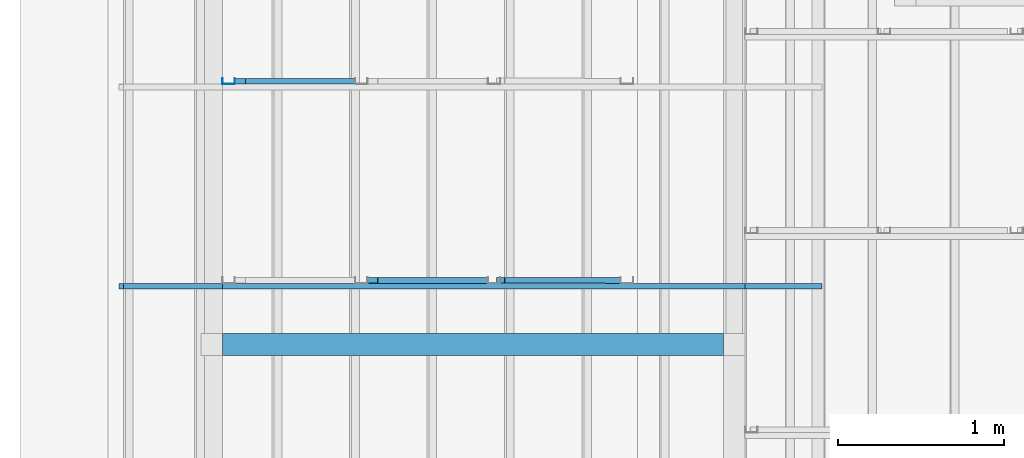
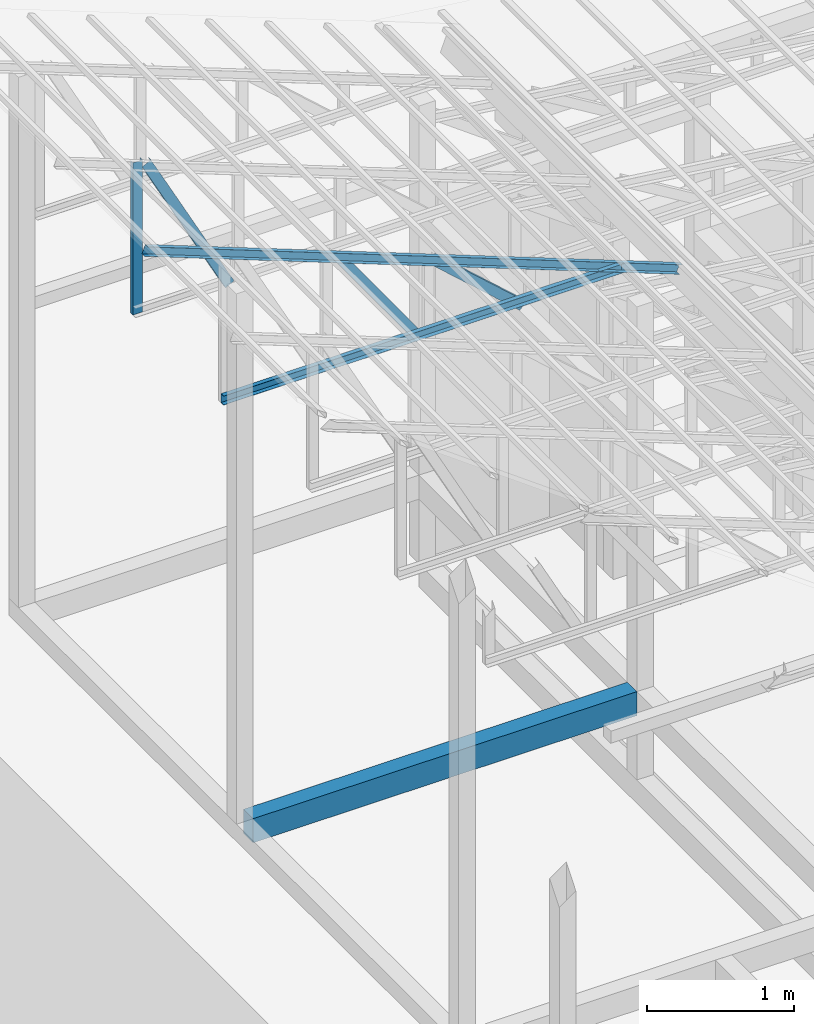
# One storey, part 12 of 22: 6 members, 1 beam, 1 element without a shape of its own.
"""IFC4 building model written with IfcOpenShell, lengths in millimetres."""

from ifc_helpers import new_model, entity, si_unit, converted_unit, frame, origin_with_axes, origin_2d_with_axis, place, context, subcontext, project, spatial, indexed_curve, c_section, outline, extrude, material, material_profile, profile_set, profile_usage, type_object, element, aggregate, save


model = new_model("IFC4")

# Units and contexts
model_context = context("Model", 3, precision=1e-05, world=origin_with_axes())
plan_context = context("Plan", 2, precision=1e-05, world=origin_2d_with_axis())
body_context = subcontext(model_context, "Body", "Model", "MODEL_VIEW")
ifc_project = project(units=[si_unit("VOLUMEUNIT", "CUBIC_METRE"), si_unit("LENGTHUNIT", "METRE", prefix="MILLI"), si_unit("AREAUNIT", "SQUARE_METRE"), converted_unit("PLANEANGLEUNIT", "degree", entity("IfcReal", 0.0174532925199433), si_unit("PLANEANGLEUNIT", "RADIAN"), dimensions=[0, 0, 0, 0, 0, 0, 0])], contexts=[model_context, plan_context])

# Site, building, storey
site_placement = place(None, origin_with_axes())
site = spatial("IfcSite", under=ifc_project, at=site_placement)
building_placement = place(site_placement, origin_with_axes())
building = spatial("IfcBuilding", under=site, at=building_placement, Name="2")
storey_placement = place(building_placement, frame((0.0, 0.0, 200.000002980232), z_axis=(0.0, 0.0, 1.0), x_axis=(1.0, 0.0, 0.0)))
storey = spatial("IfcBuildingStorey", under=building, at=storey_placement)

# Beam
ifc_material_1 = material(Name="Concrete")
ifc_material_profile_1 = material_profile(ifc_material_1, outline(indexed_curve([(-65.0, 99.9999923706055), (65.0, 99.9999923706055), (65.0, -99.9999923706055), (-65.0, -99.9999923706055), (-65.0, 99.9999923706055)])))
ifc_profile_set_1 = profile_set([ifc_material_profile_1])
ifc_profile_usage_1 = profile_usage(ifc_profile_set_1, cardinal=2)
beam_type = type_object("IfcBeamType", PredefinedType="BEAM", material=ifc_profile_set_1)
beam_placement = place(storey_placement, frame((-7084.99765396118, 14330.005645752, 535.000070929528), z_axis=(0.999999999999932, -1.9470714107682e-07, 3.13916473260157e-07), x_axis=(1.94707183709391e-07, 0.99999999999997, -1.49011611938472e-07)))
element("IfcBeam", 1, at=beam_placement, inside=storey, type_object=beam_type, material=ifc_profile_usage_1, Name="Beam", PredefinedType="BEAM", context=body_context, shape_type="SweptSolid", body=[
    extrude(outline(indexed_curve([(-65.0, 99.9999923706055), (65.0, 99.9999923706055), (65.0, -99.9999923706055), (-65.0, -99.9999923706055), (-65.0, 99.9999923706055)])), frame((0.0, 100.0, 0.0), z_axis=(0.0, 0.0, 1.0), x_axis=(1.0, 0.0, 0.0)), (0.0, 0.0, 1.0), 3020.00196570558),
])

# Assembly, members
assembly_placement = place(storey_placement, frame((-3938.51041793823, 5099.00283813477, 3935.3459328413), z_axis=(0.0, 0.0, 1.0), x_axis=(1.0, 0.0, 0.0)))
assembly = element("IfcElementAssembly", 2, at=assembly_placement, inside=storey, Name="2")
ifc_material_2 = material(Name="STEEL")
ifc_material_profile_2 = material_profile(ifc_material_2, c_section(Depth=75.0, Width=35.0, WallThickness=1.0, Girth=1.0, kind="CURVE"))
ifc_profile_set_2 = profile_set([ifc_material_profile_2])
ifc_profile_usage_2 = profile_usage(ifc_profile_set_2, cardinal=1)
member_type = type_object("IfcMemberType", Name="C75", PredefinedType="CHORD", material=ifc_profile_set_2)
member_1_placement = place(assembly_placement, frame((3.51285934448242, 9564.99862670898, -1.35517120361328), z_axis=(-0.999999999999812, -4.33125762810878e-07, 4.33125762810878e-07), x_axis=(4.33125762810919e-07, -0.999999999999906, -1.13742348872837e-13)))
member_1 = element("IfcMember", 3, at=member_1_placement, type_object=member_type, material=ifc_profile_usage_2, Name="Member", context=body_context, shape_type="SweptSolid", body=[
    extrude(c_section(Depth=75.0, Width=35.0, WallThickness=1.0, Girth=1.0, kind="CURVE"), frame((-17.5, 37.5, 0.0), z_axis=(0.0, 0.0, 1.0), x_axis=(1.0, 0.0, 0.0)), (0.0, 0.0, 1.0), 3150.02386296032),
])
ifc_profile_usage_3 = profile_usage(ifc_profile_set_2, cardinal=7)
member_2_placement = place(assembly_placement, frame((-1445.26290893555, 9635.95962524414, 624.074935913086), z_axis=(0.745142107017777, -0.00102660805644996, -0.66690493057482), x_axis=(0.00137753843534741, 0.999999051193456, -2.17762747561669e-07)))
member_2 = element("IfcMember", 4, at=member_2_placement, type_object=member_type, material=ifc_profile_usage_3, Name="Member", context=body_context, shape_type="SweptSolid", body=[
    extrude(c_section(Depth=75.0, Width=35.0, WallThickness=1.0, Girth=1.0, kind="CURVE"), frame((-17.5, -37.5, 0.0), z_axis=(0.0, 0.0, 1.0), x_axis=(1.0, 0.0, 0.0)), (0.0, 0.0, 1.0), 937.808496265298),
])
ifc_profile_usage_4 = profile_usage(ifc_profile_set_2, cardinal=1)
member_3_placement = place(assembly_placement, frame((438.234329223633, 9564.9995803833, -169.034004211426), z_axis=(-0.933001152035968, -8.32115964913738e-07, 0.359873380925658), x_axis=(9.09962921013707e-07, -0.999999999999585, 4.6906695416718e-08)))
member_3 = element("IfcMember", 5, at=member_3_placement, type_object=member_type, material=ifc_profile_usage_4, Name="Member", context=body_context, shape_type="SweptSolid", body=[
    extrude(c_section(Depth=75.0, Width=35.0, WallThickness=1.0, Girth=1.0, kind="CURVE"), frame((-17.5, 37.5, 0.0), z_axis=(0.0, 0.0, 1.0), x_axis=(1.0, 0.0, 0.0)), (0.0, 0.0, 1.0), 4510.0754953159),
])
ifc_profile_usage_5 = profile_usage(ifc_profile_set_2, cardinal=3)
member_4_placement = place(assembly_placement, frame((-2271.51107788086, 9599.99847412109, 894.618034362793), z_axis=(0.578723368640778, -7.49756619914683e-07, -0.815523919078103), x_axis=(1.02917226740772e-06, 0.999999999999453, -1.89020340712783e-07)))
member_4 = element("IfcMember", 6, at=member_4_placement, type_object=member_type, material=ifc_profile_usage_5, Name="Member", context=body_context, shape_type="SweptSolid", body=[
    extrude(c_section(Depth=75.0, Width=35.0, WallThickness=1.0, Girth=1.0, kind="CURVE"), frame((17.5, 37.5, 0.0), z_axis=(0.0, 0.0, 1.0), x_axis=(1.0, 0.0, 0.0)), (0.0, 0.0, 1.0), 1142.30360336039),
])
ifc_profile_usage_6 = profile_usage(ifc_profile_set_2, cardinal=1)
member_5_placement = place(assembly_placement, frame((-3146.51107788086, 10834.997177124, 1265.15865325928), z_axis=(-8.74227410463377e-08, -1.50995830949794e-07, -0.999999999999985), x_axis=(-3.13916473260159e-07, 0.999999999999939, -1.50995802528077e-07)))
member_5 = element("IfcMember", 7, at=member_5_placement, type_object=member_type, material=ifc_profile_usage_6, Name="Member", context=body_context, shape_type="SweptSolid", body=[
    extrude(c_section(Depth=75.0, Width=35.0, WallThickness=1.0, Girth=1.0, kind="CURVE"), frame((-17.5, 37.5, 0.0), z_axis=(0.0, 0.0, 1.0), x_axis=(1.0, 0.0, 0.0)), (0.0, 0.0, 1.0), 1266.51238309135),
])
ifc_profile_usage_7 = profile_usage(ifc_profile_set_2, cardinal=9)
member_6_placement = place(assembly_placement, frame((-3006.42156600952, 10799.9973297119, 1241.45650863647), z_axis=(0.468464370953309, -3.43728484817469e-07, -0.88348238983423), x_axis=(6.7154434191237e-07, 0.999999999999774, -3.29761675743537e-08)))
member_6 = element("IfcMember", 8, at=member_6_placement, type_object=member_type, material=ifc_profile_usage_7, Name="Member", context=body_context, shape_type="SweptSolid", body=[
    extrude(c_section(Depth=75.0, Width=35.0, WallThickness=1.0, Girth=1.0, kind="CURVE"), frame((17.5, -37.5, 0.0), z_axis=(0.0, 0.0, 1.0), x_axis=(1.0, 0.0, 0.0)), (0.0, 0.0, 1.0), 1399.63894386164),
])
aggregate(assembly, [member_1, member_2, member_3, member_4, member_5, member_6])

save(model, "model.ifc")
